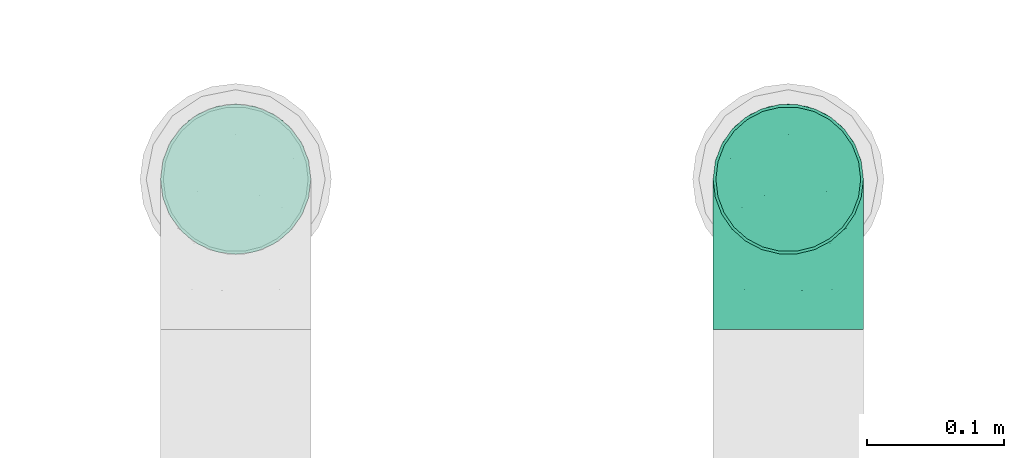
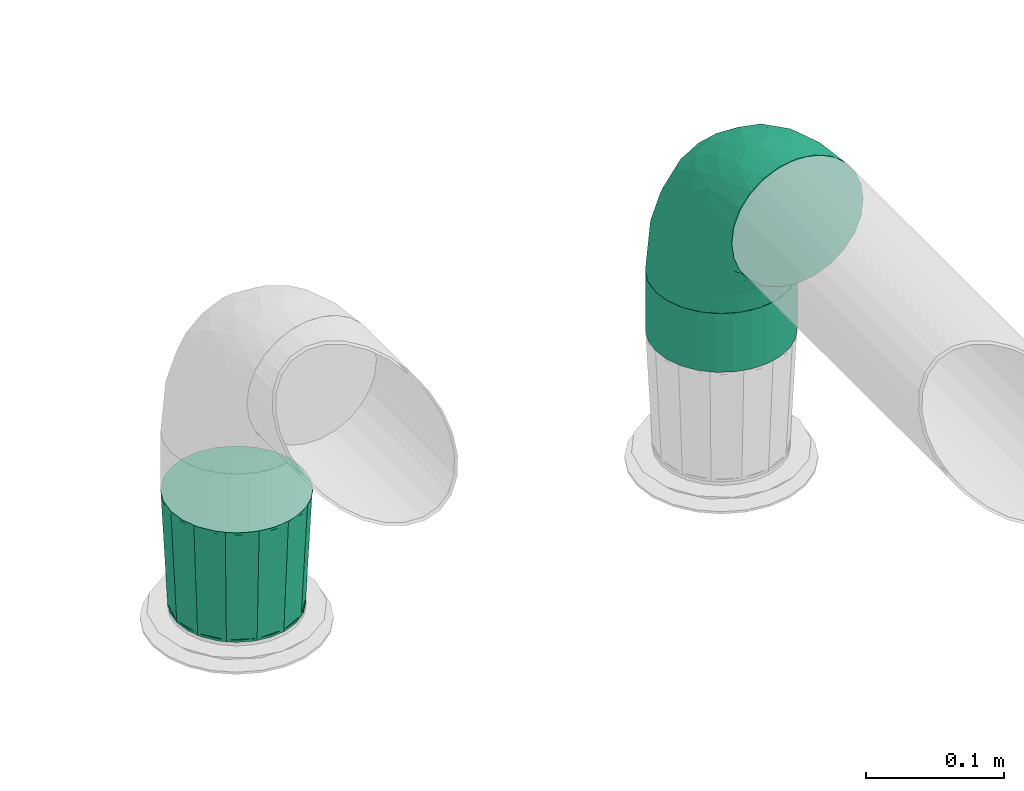
# One storey, part 33 of 115: 2 flow fittings, 1 flow segment.
"""IFC2X3 building model written with IfcOpenShell, lengths in millimetres."""

from ifc_helpers import new_model, entity, si_unit, converted_unit, derived_unit, direction, frame, origin_with_axes, origin_2d_with_axis, place, context, subcontext, project, spatial, hollow_circle, extrude, open_shell, surface_model, source, transform, mapped, material, layer, layer_set, layer_usage, type_object, element, save


model = new_model("IFC2X3")

# Units and contexts
model_context = context("Model", 3, precision=1e-05, world=origin_with_axes(), true_north=direction((0.0, 1.0)))
body_context = subcontext(model_context, "Body", "Model", "MODEL_VIEW")
ifc_project = project(units=[si_unit("AREAUNIT", "SQUARE_METRE"), si_unit("VOLUMEUNIT", "CUBIC_METRE", prefix="DECI"), si_unit("TIMEUNIT", "SECOND"), si_unit("THERMODYNAMICTEMPERATUREUNIT", "DEGREE_CELSIUS"), si_unit("PRESSUREUNIT", "PASCAL"), si_unit("MASSUNIT", "GRAM", prefix="KILO"), si_unit("LENGTHUNIT", "METRE", prefix="MILLI"), si_unit("POWERUNIT", "WATT"), si_unit("ELECTRICCURRENTUNIT", "AMPERE"), si_unit("ELECTRICVOLTAGEUNIT", "VOLT"), derived_unit("VOLUMETRICFLOWRATEUNIT", [(si_unit("VOLUMEUNIT", "CUBIC_METRE", prefix="DECI"), 1), (si_unit("TIMEUNIT", "SECOND"), -1)]), derived_unit("LINEARVELOCITYUNIT", [(si_unit("LENGTHUNIT", "METRE"), 1), (si_unit("TIMEUNIT", "SECOND"), -1)]), derived_unit("MASSDENSITYUNIT", [(si_unit("MASSUNIT", "GRAM", prefix="KILO"), 1), (si_unit("VOLUMEUNIT", "CUBIC_METRE"), -1)]), converted_unit("PLANEANGLEUNIT", "DEGREE", entity("IfcRatioMeasure", 0.01745), si_unit("PLANEANGLEUNIT", "RADIAN"), dimensions=[0, 0, 0, 0, 0, 0, 0])], contexts=[model_context])

# Site, building, storey
site_placement = place(None, origin_with_axes())
site = spatial("IfcSite", under=ifc_project, at=site_placement, CompositionType="ELEMENT")
building_placement = place(site_placement, origin_with_axes())
building = spatial("IfcBuilding", under=site, at=building_placement, Name="mc-building", CompositionType="ELEMENT")
storey_placement = place(building_placement, frame((0.0, 0.0, 2950.0), z_axis=(0.0, 0.0, 1.0), x_axis=(1.0, 0.0, 0.0)))
storey = spatial("IfcBuildingStorey", under=building, at=storey_placement, Name="2. Korrus", CompositionType="ELEMENT", Elevation=2950.0)

# Flow segment
ifc_material = material(Name="FZ1")
ifc_layer = layer(ifc_material, 0.0)
ifc_layer_set = layer_set([ifc_layer], Name="FZ1")
ifc_layer_usage = layer_usage(ifc_layer_set, "AXIS1", "POSITIVE", 0.0)
duct_segment_type = type_object("IfcDuctSegmentType", PredefinedType="RIGIDSEGMENT")
shared_shape_1 = source(origin_with_axes(), body_context, "Body", "SweptSolid", [
    extrude(hollow_circle(Radius=55.0, WallThickness=2.0, at=origin_2d_with_axis()), frame((0.0, 0.0, 0.0), z_axis=(1.0, 0.0, 0.0), x_axis=(0.0, 1.0, 0.0)), (0.0, 0.0, 1.0), 51.9),
])
flow_segment_placement = place(storey_placement, frame((16200.78197, 4393.85998, 2355.0), z_axis=(0.0, -1.0, 0.0), x_axis=(0.0, 0.0, -1.0)))
element("IfcFlowSegment", 1, at=flow_segment_placement, inside=storey, type_object=duct_segment_type, material=ifc_layer_usage, context=body_context, shape_type="MappedRepresentation", body=[
    mapped(shared_shape_1, transform((0.0, 0.0, 0.0), scale=1.0)),
])

# Flow fittings
duct_fitting_type_1 = type_object("IfcDuctFittingType", Name="BU", PredefinedType="BEND")
shared_shape_2 = source(origin_with_axes(), body_context, "Body", "SurfaceModel", [
    surface_model("IfcShellBasedSurfaceModel", [(-110.0, 0.0, -55.0), (-110.0, -14.23505, -53.12592), (-110.0, 14.23505, -53.12592), (-110.0, 53.12592, 14.23505), (-110.0, 27.5, -47.63139), (-110.0, 38.89087, -38.89087), (-110.0, -55.0, 0.0), (-110.0, -53.12592, 14.23505), (-110.0, -38.89087, -38.89087), (-110.0, -27.5, -47.63139), (-110.0, -53.12592, -14.23505), (-110.0, -47.63139, -27.5), (-110.0, -14.23505, 53.12592), (-110.0, 14.23505, 53.12592), (-110.0, 27.5, 47.63139), (-110.0, -47.63139, 27.5), (-110.0, -38.89087, 38.89087), (-110.0, -27.5, 47.63139), (-110.0, 0.0, 55.0), (-110.0, 55.0, 0.0), (-110.0, 53.12592, -14.23505), (-110.0, 47.63139, -27.5), (-110.0, 47.63139, 27.5), (-110.0, 38.89087, 38.89087), (-14.23505, 110.0, -53.12592), (-55.0, 110.0, 0.0), (0.0, 110.0, -55.0), (-27.5, 110.0, -47.63139), (-38.89087, 110.0, -38.89087), (-47.63139, 110.0, -27.5), (38.89087, 110.0, -38.89087), (53.12592, 110.0, 14.23505), (27.5, 110.0, -47.63139), (14.23505, 110.0, -53.12592), (47.63139, 110.0, -27.5), (53.12592, 110.0, -14.23505), (55.0, 110.0, 0.0), (-53.12592, 110.0, -14.23505), (-53.12592, 110.0, 14.23505), (-47.63139, 110.0, 27.5), (-38.89087, 110.0, 38.89087), (-27.5, 110.0, 47.63139), (0.0, 110.0, 55.0), (-14.23505, 110.0, 53.12592), (38.89087, 110.0, 38.89087), (47.63139, 110.0, 27.5), (27.5, 110.0, 47.63139), (14.23505, 110.0, 53.12592), (-64.21732, 48.68956, 43.63444), (-76.6405, 38.18013, 45.55988), (-60.44912, 32.56953, 51.94617), (-76.00813, 5.38378, 55.0), (-90.15553, 11.94394, 54.09138), (-78.5998, 26.77405, 50.81338), (-70.18771, 18.55163, 54.03432), (-75.55424, 54.2118, 32.41257), (-93.27622, 45.77614, 33.48188), (-96.12334, 22.13664, 50.81337), (-21.00813, 45.34362, 55.0), (-18.36258, 70.48427, 54.04484), (-32.04182, 59.64019, 52.24446), (-63.88653, 74.77858, 17.99134), (-74.66383, 63.08407, 19.92123), (-63.60674, 66.07878, 29.97482), (-99.597, 52.72185, 18.52927), (-93.11138, 56.59448, 10.50359), (-98.21577, 57.34403, 0.0), (-53.42855, 92.60092, 21.04759), (-88.54852, 54.8376, 21.04759), (-11.86161, 90.23965, 54.10313), (-5.38378, 76.00813, 55.0), (-57.34403, 98.21577, 0.0), (-56.64619, 93.12774, 10.22088), (-45.34362, 21.00813, 55.0), (-44.60838, 44.60838, 52.13415), (-92.68484, 35.46673, 43.63443), (-22.25266, 95.40765, 50.81337), (-35.97783, 90.61597, 43.63443), (-43.70931, 69.58671, 44.47149), (-27.23711, 77.39884, 50.81337), (-57.2828, 79.3123, 24.9774), (-58.67786, 84.31125, 16.04456), (-82.93277, 60.36161, 12.91784), (-49.88337, 54.51816, 47.224), (-74.57753, 66.83759, 9.55742), (-45.35812, 94.97281, 33.48188), (-59.18663, 88.95241, 0.0), (-51.517, 78.6292, 33.48188), (-65.14788, 80.03077, 0.0), (-56.45322, 62.06476, 39.63545), (-88.95241, 59.18663, 0.0), (-71.10913, 71.10913, 0.0), (-80.03077, 65.14788, 0.0), (-94.9309, 45.36788, -33.48188), (-93.11358, 56.60141, -10.46614), (-99.64997, 52.79499, -18.30015), (-90.20425, 36.08686, -43.63443), (-79.99933, 46.56772, -37.92748), (-76.00813, 5.38378, -55.0), (-72.75364, 19.68651, -53.60527), (-45.34362, 21.00813, -55.0), (-21.91957, 65.12078, -53.85897), (-5.38378, 76.00813, -55.0), (-21.00813, 45.34362, -55.0), (-35.41876, 92.89265, -43.63443), (-91.10309, 11.02766, -54.21832), (-45.77614, 93.27622, -33.48188), (-90.50474, 23.21022, -50.81337), (-70.92854, 33.31794, -49.51754), (-78.52933, 63.35627, -11.73997), (-24.91508, 84.05606, -50.81337), (-88.78941, 54.74452, -21.04759), (-69.59921, 57.34866, -33.48187), (-73.36422, 62.46673, -22.94182), (-63.49062, 67.59111, -28.46929), (-56.59448, 93.11138, -10.50359), (-54.8376, 88.54852, -21.04759), (-54.10679, 75.85581, -32.31867), (-57.75956, 31.09612, -52.80882), (-52.72185, 99.597, -18.52927), (-12.62913, 89.46304, -53.99097), (-34.46825, 66.46123, -50.04329), (-43.9837, 43.9837, -52.42279), (-65.78527, 72.58348, -17.68796), (-70.34468, 43.65295, -44.21951), (-57.47001, 51.99467, -44.91465), (-60.72547, 82.29174, -12.88567), (-42.34915, 74.24548, -43.63444), (-57.25194, 63.5016, -38.08211), (-80.95344, 53.56991, -29.32027), (-52.32891, 4.55257, -54.0482), (32.52942, 47.13398, -30.48571), (14.88266, 20.92917, -33.7947), (14.95561, 36.05775, -42.26543), (30.24048, 70.09027, -41.7461), (19.3559, 65.35825, -48.00507), (-70.35075, -46.44478, -19.5952), (-47.13398, -32.52942, -30.48571), (-28.49299, -30.5778, -16.4009), (-4.55257, 52.32891, -54.0482), (-22.4954, 22.4954, -53.25347), (-75.47368, -11.22546, -52.60718), (-81.32209, -51.5606, -9.98467), (-80.81763, -41.84862, -32.14655), (-70.09027, -30.24048, -41.7461), (-36.05774, -14.95561, -42.26543), (-9.15831, -10.852, -27.8997), (-65.35825, -19.3559, -48.00507), (11.22546, 75.47368, -52.60718), (3.94376, 43.9333, -50.53315), (-13.39742, 13.39743, -48.13058), (-43.9333, -3.94376, -50.53315), (49.37776, 67.29486, 0.0), (41.8609, 47.82256, -9.92641), (50.20582, 74.51695, -9.9731), (18.93131, 11.7156, -17.56239), (-27.5, -32.89419, 0.0), (-1.23348, -12.25375, -12.18106), (41.84862, 80.81763, -32.14655), (35.70604, 41.31408, -20.38235), (46.44478, 70.35075, -19.5952), (32.89419, 27.5, 0.0), (6.67262, -6.67262, 0.0), (-67.29486, -49.37776, 0.0), (-50.36265, -42.95545, -9.51562), (-5.47251, 5.47251, -39.92906), (-70.35075, -46.44478, 19.5952), (-74.51695, -50.20582, 9.9731), (-41.31407, -35.70604, 20.38235), (-47.13398, -32.52942, 30.48571), (-80.81763, -41.84862, 32.14655), (-4.55257, 52.32891, 54.0482), (11.22546, 75.47368, 52.60718), (-43.9333, -3.94376, 50.53315), (-65.35825, -19.3559, 48.00507), (-36.05774, -14.95561, 42.26543), (-70.09027, -30.24048, 41.7461), (-11.7156, -18.93131, 17.56239), (30.5778, 28.49299, 16.4009), (12.25375, 1.23348, 12.18106), (51.5606, 81.32209, 9.98467), (42.95545, 50.36265, 9.51562), (-75.47368, -11.22546, 52.60718), (-52.32891, 4.55257, 54.0482), (3.94376, 43.9333, 50.53315), (-22.4954, 22.4954, 53.25347), (-13.39742, 13.39743, 48.13058), (10.852, 9.15831, 27.8997), (-20.92916, -14.88266, 33.79469), (-47.82256, -41.8609, 9.92641), (32.52942, 47.13398, 30.48571), (46.44478, 70.35075, 19.5952), (41.84862, 80.81763, 32.14655), (30.24048, 70.09027, 41.7461), (19.3559, 65.35825, 48.00507), (14.95561, 36.05775, 42.26543), (-5.47251, 5.47251, 39.92906)], [open_shell([[[0, 1, 2]], [[2, 3, 4]], [[4, 3, 5]], [[2, 6, 7]], [[8, 6, 9]], [[1, 9, 6]], [[10, 6, 11]], [[8, 11, 6]], [[6, 2, 1]], [[12, 13, 14]], [[15, 2, 7]], [[16, 17, 2]], [[2, 17, 12]], [[12, 18, 13]], [[19, 20, 3]], [[5, 3, 21]], [[20, 21, 3]], [[22, 3, 2]], [[23, 22, 2]], [[12, 14, 2]], [[2, 14, 23]], [[15, 16, 2]], [[24, 25, 26]], [[27, 25, 24]], [[25, 28, 29]], [[28, 25, 27]], [[30, 26, 31]], [[26, 30, 32]], [[32, 33, 26]], [[34, 31, 35]], [[31, 34, 30]], [[35, 31, 36]], [[29, 37, 25]], [[38, 39, 26]], [[39, 40, 26]], [[41, 42, 40]], [[42, 26, 40]], [[42, 41, 43]], [[26, 44, 45]], [[31, 26, 45]], [[26, 46, 44]], [[47, 46, 26]], [[42, 47, 26]], [[25, 38, 26]], [[48, 49, 50]], [[18, 51, 52]], [[53, 54, 50]], [[55, 56, 49]], [[56, 22, 23]], [[13, 57, 14]], [[58, 59, 60]], [[61, 62, 63]], [[3, 64, 65]], [[53, 52, 54]], [[3, 65, 66]], [[67, 39, 38]], [[56, 68, 64]], [[65, 64, 68]], [[69, 59, 70]], [[38, 71, 72]], [[73, 58, 74]], [[75, 49, 56]], [[76, 69, 43]], [[53, 57, 52]], [[77, 78, 79]], [[41, 76, 43]], [[43, 69, 42]], [[55, 68, 56]], [[23, 14, 75]], [[76, 77, 79]], [[80, 67, 81]], [[62, 82, 68]], [[60, 78, 83]], [[62, 84, 82]], [[85, 77, 40]], [[81, 67, 72]], [[86, 72, 71]], [[87, 85, 67]], [[61, 81, 88]], [[77, 41, 40]], [[78, 77, 87]], [[23, 75, 56]], [[83, 89, 48]], [[85, 40, 39]], [[62, 68, 55]], [[89, 87, 63]], [[83, 48, 50]], [[57, 75, 14]], [[49, 75, 53]], [[67, 85, 39]], [[87, 77, 85]], [[63, 62, 55]], [[89, 55, 48]], [[80, 63, 87]], [[66, 65, 90]], [[66, 19, 3]], [[84, 91, 92]], [[92, 90, 82]], [[65, 82, 90]], [[61, 84, 62]], [[92, 82, 84]], [[68, 82, 65]], [[3, 22, 64]], [[56, 64, 22]], [[38, 25, 71]], [[81, 72, 86]], [[38, 72, 67]], [[91, 61, 88]], [[80, 81, 61]], [[63, 80, 61]], [[67, 80, 87]], [[77, 76, 41]], [[79, 59, 69]], [[79, 69, 76]], [[42, 69, 70]], [[60, 59, 79]], [[58, 70, 59]], [[78, 60, 79]], [[58, 60, 74]], [[52, 57, 13]], [[75, 57, 53]], [[18, 52, 13]], [[52, 51, 54]], [[51, 73, 54]], [[50, 73, 74]], [[73, 50, 54]], [[50, 74, 83]], [[60, 83, 74]], [[89, 83, 78]], [[87, 89, 78]], [[55, 89, 63]], [[50, 49, 53]], [[55, 49, 48]], [[81, 86, 88]], [[91, 84, 61]], [[5, 21, 93]], [[90, 94, 66]], [[20, 94, 95]], [[96, 93, 97]], [[98, 99, 100]], [[96, 4, 5]], [[101, 102, 103]], [[28, 27, 104]], [[2, 105, 0]], [[104, 106, 28]], [[99, 105, 107]], [[108, 107, 96]], [[90, 109, 94]], [[107, 2, 4]], [[20, 66, 94]], [[27, 24, 110]], [[109, 111, 94]], [[112, 113, 114]], [[37, 115, 71]], [[116, 106, 117]], [[99, 118, 100]], [[116, 115, 119]], [[37, 119, 115]], [[24, 120, 110]], [[121, 110, 101]], [[119, 106, 116]], [[101, 110, 120]], [[122, 103, 100]], [[117, 123, 116]], [[124, 125, 108]], [[115, 116, 126]], [[106, 29, 28]], [[26, 102, 120]], [[127, 104, 110]], [[97, 124, 96]], [[125, 122, 118]], [[128, 127, 125]], [[96, 5, 93]], [[115, 126, 86]], [[117, 106, 127]], [[111, 113, 129]], [[95, 93, 21]], [[97, 129, 112]], [[110, 104, 27]], [[106, 104, 127]], [[96, 107, 4]], [[99, 107, 108]], [[99, 108, 118]], [[105, 99, 98]], [[112, 114, 128]], [[121, 125, 127]], [[20, 19, 66]], [[109, 90, 92]], [[94, 111, 95]], [[91, 123, 109]], [[129, 113, 112]], [[93, 95, 111]], [[21, 20, 95]], [[71, 115, 86]], [[71, 25, 37]], [[123, 91, 88]], [[126, 116, 123]], [[123, 88, 126]], [[86, 126, 88]], [[37, 29, 119]], [[106, 119, 29]], [[129, 93, 111]], [[124, 112, 125]], [[0, 105, 98]], [[107, 105, 2]], [[125, 118, 108]], [[100, 118, 122]], [[93, 129, 97]], [[113, 111, 109]], [[109, 123, 113]], [[114, 123, 117]], [[123, 114, 113]], [[128, 114, 117]], [[127, 128, 117]], [[112, 128, 125]], [[103, 122, 101]], [[110, 121, 127]], [[101, 122, 121]], [[125, 121, 122]], [[26, 120, 24]], [[101, 120, 102]], [[96, 124, 108]], [[92, 91, 109]], [[112, 124, 97]], [[100, 130, 98]], [[131, 132, 133]], [[32, 134, 135]], [[136, 137, 138]], [[139, 140, 103]], [[98, 141, 0]], [[142, 10, 136]], [[143, 144, 137]], [[6, 10, 142]], [[137, 145, 146]], [[144, 147, 145]], [[143, 136, 11]], [[11, 136, 10]], [[8, 143, 11]], [[148, 149, 139]], [[8, 9, 144]], [[9, 1, 147]], [[130, 141, 98]], [[103, 140, 100]], [[148, 135, 149]], [[150, 151, 140]], [[152, 153, 154]], [[130, 140, 151]], [[148, 26, 33]], [[147, 1, 141]], [[155, 146, 132]], [[156, 138, 157]], [[134, 30, 158]], [[150, 140, 149]], [[158, 30, 34]], [[30, 134, 32]], [[153, 159, 160]], [[131, 160, 159]], [[144, 145, 137]], [[36, 152, 154]], [[146, 138, 137]], [[155, 161, 162]], [[158, 160, 131]], [[133, 149, 135]], [[156, 163, 164]], [[163, 142, 164]], [[139, 103, 102]], [[153, 152, 161]], [[34, 35, 160]], [[162, 157, 155]], [[132, 165, 133]], [[157, 146, 155]], [[140, 130, 100]], [[141, 130, 151]], [[141, 151, 147]], [[141, 1, 0]], [[102, 26, 148]], [[140, 139, 149]], [[102, 148, 139]], [[135, 33, 32]], [[151, 150, 145]], [[9, 147, 144]], [[151, 145, 147]], [[145, 165, 146]], [[135, 148, 33]], [[133, 135, 134]], [[131, 133, 134]], [[133, 165, 150]], [[133, 150, 149]], [[145, 150, 165]], [[132, 131, 159]], [[146, 165, 132]], [[160, 158, 34]], [[134, 158, 131]], [[144, 143, 8]], [[136, 143, 137]], [[155, 153, 161]], [[154, 153, 160]], [[153, 155, 159]], [[132, 159, 155]], [[160, 35, 154]], [[36, 154, 35]], [[164, 136, 138]], [[6, 142, 163]], [[136, 164, 142]], [[156, 164, 138]], [[156, 157, 162]], [[146, 157, 138]], [[15, 7, 166]], [[6, 163, 167]], [[168, 169, 166]], [[166, 169, 170]], [[171, 172, 70]], [[173, 174, 175]], [[17, 176, 174]], [[177, 156, 162]], [[176, 16, 170]], [[170, 16, 15]], [[161, 178, 179]], [[152, 180, 181]], [[182, 173, 183]], [[18, 12, 182]], [[184, 185, 186]], [[183, 185, 73]], [[183, 73, 51]], [[177, 187, 188]], [[189, 168, 166]], [[187, 178, 190]], [[16, 176, 17]], [[161, 152, 181]], [[45, 191, 31]], [[45, 44, 192]], [[192, 191, 45]], [[180, 36, 31]], [[193, 194, 195]], [[46, 47, 194]], [[193, 195, 190]], [[193, 44, 46]], [[172, 42, 70]], [[185, 58, 73]], [[189, 163, 156]], [[163, 189, 167]], [[70, 58, 171]], [[184, 171, 185]], [[169, 188, 175]], [[180, 31, 191]], [[192, 193, 190]], [[191, 190, 178]], [[182, 174, 173]], [[194, 47, 172]], [[190, 195, 187]], [[186, 185, 173]], [[162, 179, 177]], [[188, 196, 175]], [[179, 187, 177]], [[185, 171, 58]], [[172, 171, 184]], [[172, 184, 194]], [[172, 47, 42]], [[51, 18, 182]], [[185, 183, 173]], [[51, 182, 183]], [[174, 12, 17]], [[184, 186, 195]], [[46, 194, 193]], [[184, 195, 194]], [[195, 196, 187]], [[174, 182, 12]], [[175, 174, 176]], [[169, 175, 176]], [[175, 196, 186]], [[175, 186, 173]], [[195, 186, 196]], [[188, 169, 168]], [[187, 196, 188]], [[166, 170, 15]], [[176, 170, 169]], [[193, 192, 44]], [[191, 192, 190]], [[177, 189, 156]], [[167, 189, 166]], [[189, 177, 168]], [[188, 168, 177]], [[166, 7, 167]], [[6, 167, 7]], [[181, 191, 178]], [[36, 180, 152]], [[191, 181, 180]], [[161, 181, 178]], [[161, 179, 162]], [[187, 179, 178]]])]),
])
flow_fitting_1_placement = place(storey_placement, frame((16200.78197, 4393.85998, 2465.0), z_axis=(-1.0, 0.0, 0.0), x_axis=(0.0, 1.0, 0.0)))
element("IfcFlowFitting", 2, at=flow_fitting_1_placement, inside=storey, type_object=duct_fitting_type_1, Name="BU", context=body_context, shape_type="MappedRepresentation", body=[
    mapped(shared_shape_2, transform((0.0, 0.0, 0.0), scale=1.0)),
])
duct_fitting_type_2 = type_object("IfcDuctFittingType", PredefinedType="TRANSITION")
shared_shape_3 = source(origin_with_axes(), body_context, "Body", "SurfaceModel", [
    surface_model("IfcShellBasedSurfaceModel", [(100.0, -55.0, 0.0), (100.0, -12.23865, 53.62104), (100.0, -34.29194, 43.00073), (100.0, 49.55329, 23.86361), (100.0, 34.29194, 43.00073), (100.0, 49.55329, -23.86361), (0.0, -45.04844, -21.69419), (0.0, -50.0, 0.0), (0.0, -45.04844, 21.69419), (0.0, 31.17449, 39.09157), (0.0, 45.04844, 21.69419), (0.0, 50.0, 0.0), (98.0, 47.63139, 27.5), (98.0, 0.0, 55.0), (98.0, 38.89087, 38.89087), (98.0, -38.89087, 38.89087), (98.0, -47.63139, 27.5), (100.0, 12.23865, 53.62104), (100.0, -49.55329, 23.86361), (100.0, 55.0, 0.0), (100.0, 12.23865, -53.62104), (100.0, 34.29194, -43.00073), (100.0, -49.55329, -23.86361), (100.0, -34.29194, -43.00073), (100.0, -12.23865, -53.62104), (0.0, -31.17449, 39.09157), (0.0, -11.12605, 48.7464), (0.0, 11.12605, 48.7464), (0.0, -31.17449, -39.09157), (0.0, 11.12605, -48.7464), (0.0, -11.12605, -48.7464), (0.0, 45.04844, -21.69419), (0.0, 31.17449, -39.09157), (0.0, 47.52422, -10.84709), (0.0, 38.11147, -30.39288), (100.0, 41.92261, -33.43217), (100.0, -41.92261, -33.43217), (0.0, -38.11147, -30.39288), (100.0, 23.2653, -48.31088), (0.0, 21.15027, -43.91899), (100.0, 52.32388, -11.72483), (0.0, 0.0, -48.7464), (100.0, 0.0, -53.62104), (0.0, -21.15027, -43.91899), (100.0, -23.2653, -48.31088), (0.0, -47.52422, -10.84709), (100.0, -52.32388, -11.72483), (0.0, -47.52422, 10.84709), (0.0, -38.11147, 30.39288), (100.0, -41.92261, 33.43217), (100.0, 41.92261, 33.43217), (0.0, 38.11147, 30.39288), (100.0, -23.2653, 48.31088), (0.0, -21.15027, 43.91899), (100.0, -52.32388, 11.72483), (0.0, 0.0, 48.7464), (100.0, 0.0, 53.62104), (0.0, 21.15027, 43.91899), (100.0, 23.2653, 48.31088), (0.0, 47.52422, 10.84709), (100.0, 52.32388, 11.72483), (100.0, -14.23505, -53.12592), (100.0, 0.0, -55.0), (100.0, -27.5, -47.63139), (100.0, 27.5, -47.63139), (100.0, -38.89087, -38.89087), (100.0, -53.12592, -14.23505), (100.0, -47.63139, -27.5), (100.0, -47.63139, 27.5), (100.0, 14.23505, -53.12592), (100.0, 38.89087, -38.89087), (100.0, 47.63139, -27.5), (100.0, 47.63139, 27.5), (100.0, 53.12592, -14.23505), (100.0, -53.12592, 14.23505), (100.0, -38.89087, 38.89087), (100.0, -27.5, 47.63139), (100.0, 0.0, 55.0), (100.0, -14.23505, 53.12592), (100.0, 53.12592, 14.23505), (100.0, 38.89087, 38.89087), (100.0, 27.5, 47.63139), (100.0, 14.23505, 53.12592), (98.0, -27.5, 47.63139), (98.0, -14.23505, 53.12592), (98.0, -53.12592, -14.23505), (98.0, 14.23505, 53.12592), (98.0, 27.5, 47.63139), (98.0, 53.12592, 14.23505), (98.0, 55.0, 0.0), (98.0, -47.63139, -27.5), (98.0, -53.12592, 14.23505), (98.0, 27.5, -47.63139), (98.0, -27.5, -47.63139), (98.0, -38.89087, -38.89087), (98.0, 0.0, -55.0), (98.0, -14.23505, -53.12592), (98.0, 38.89087, -38.89087), (98.0, 47.63139, -27.5), (98.0, 53.12592, -14.23505), (98.0, 14.23505, -53.12592), (98.0, -55.0, 0.0), (0.0, 0.0, 50.0), (0.0, 35.35534, 35.35534), (0.0, -12.94095, 48.29629), (0.0, -25.0, 43.30127), (0.0, -35.35534, 35.35534), (0.0, -48.29629, 12.94095), (0.0, -43.30127, 25.0), (0.0, 25.0, 43.30127), (0.0, 12.94095, 48.29629), (0.0, 43.30127, 25.0), (0.0, 48.29629, 12.94095), (0.0, 25.0, -43.30127), (0.0, 48.29629, -12.94095), (0.0, -48.29629, -12.94095), (0.0, -43.30127, -25.0), (0.0, -12.94095, -48.29629), (0.0, -25.0, -43.30127), (0.0, -35.35534, -35.35534), (0.0, 43.30127, -25.0), (0.0, 35.35534, -35.35534), (0.0, 12.94095, -48.29629), (0.0, 0.0, -50.0), (2.0, -35.35534, -35.35534), (2.0, -25.0, -43.30127), (2.0, -12.94095, -48.29629), (2.0, -43.30127, -25.0), (2.0, 0.0, -50.0), (2.0, -48.29629, -12.94095), (2.0, -50.0, 0.0), (2.0, 12.94095, -48.29629), (2.0, 25.0, -43.30127), (2.0, 43.30127, -25.0), (2.0, 48.29629, -12.94095), (2.0, 35.35534, -35.35534), (2.0, -48.29629, 12.94095), (2.0, -35.35534, 35.35534), (2.0, -43.30127, 25.0), (2.0, 35.35534, 35.35534), (2.0, -12.94095, 48.29629), (2.0, -25.0, 43.30127), (2.0, 0.0, 50.0), (2.0, 43.30127, 25.0), (2.0, 48.29629, 12.94095), (2.0, 50.0, 0.0), (2.0, 25.0, 43.30127), (2.0, 12.94095, 48.29629)], [open_shell([[[0, 1, 2]], [[3, 4, 5]], [[6, 7, 8]], [[9, 10, 11]], [[12, 13, 14]], [[15, 13, 16]], [[0, 4, 17]], [[2, 18, 0]], [[1, 0, 17]], [[3, 5, 19]], [[20, 21, 5]], [[22, 20, 5]], [[22, 5, 0]], [[22, 23, 24]], [[22, 24, 20]], [[4, 0, 5]], [[8, 25, 6]], [[6, 25, 26]], [[6, 26, 27]], [[11, 27, 9]], [[28, 6, 29]], [[30, 28, 29]], [[31, 6, 11]], [[31, 32, 29]], [[31, 29, 6]], [[27, 11, 6]], [[31, 33, 5]], [[34, 35, 32]], [[36, 22, 6]], [[36, 37, 23]], [[38, 29, 39]], [[33, 40, 5]], [[33, 11, 40]], [[19, 40, 11]], [[32, 21, 39]], [[32, 35, 21]], [[34, 31, 35]], [[30, 41, 42]], [[28, 43, 44]], [[42, 41, 20]], [[7, 45, 46]], [[38, 39, 21]], [[46, 0, 7]], [[6, 37, 36]], [[38, 20, 29]], [[43, 30, 24]], [[42, 24, 30]], [[28, 23, 37]], [[6, 22, 45]], [[35, 31, 5]], [[44, 43, 24]], [[20, 41, 29]], [[46, 45, 22]], [[44, 23, 28]], [[8, 47, 18]], [[48, 49, 25]], [[50, 3, 10]], [[50, 51, 4]], [[52, 26, 53]], [[47, 54, 18]], [[47, 7, 54]], [[0, 54, 7]], [[25, 2, 53]], [[25, 49, 2]], [[48, 8, 49]], [[27, 55, 56]], [[9, 57, 58]], [[56, 55, 1]], [[11, 59, 60]], [[52, 53, 2]], [[60, 19, 11]], [[10, 51, 50]], [[52, 1, 26]], [[57, 27, 17]], [[56, 17, 27]], [[9, 4, 51]], [[10, 3, 59]], [[49, 8, 18]], [[58, 57, 17]], [[1, 55, 26]], [[60, 59, 3]], [[58, 4, 9]], [[61, 62, 63]], [[63, 64, 65]], [[66, 67, 68]], [[65, 64, 67]], [[67, 64, 68]], [[69, 64, 62]], [[64, 63, 62]], [[70, 71, 64]], [[72, 64, 71]], [[71, 73, 19]], [[74, 0, 66]], [[72, 68, 64]], [[75, 68, 76]], [[77, 78, 76]], [[72, 76, 68]], [[76, 72, 77]], [[79, 72, 19]], [[19, 72, 71]], [[80, 81, 77]], [[77, 72, 80]], [[82, 77, 81]], [[74, 66, 68]], [[83, 84, 13]], [[15, 83, 13]], [[12, 16, 13]], [[16, 12, 85]], [[86, 87, 13]], [[87, 14, 13]], [[88, 89, 12]], [[89, 90, 12]], [[91, 16, 85]], [[90, 85, 12]], [[89, 92, 90]], [[93, 94, 95]], [[95, 94, 90]], [[96, 93, 95]], [[97, 92, 98]], [[98, 89, 99]], [[100, 95, 92]], [[92, 89, 98]], [[90, 92, 95]], [[101, 91, 85]], [[89, 73, 99]], [[99, 71, 98]], [[92, 97, 64]], [[70, 97, 98]], [[100, 92, 69]], [[73, 71, 99]], [[89, 19, 73]], [[92, 64, 69]], [[64, 97, 70]], [[98, 71, 70]], [[100, 69, 62]], [[62, 95, 100]], [[95, 61, 96]], [[96, 63, 93]], [[90, 94, 67]], [[65, 94, 93]], [[85, 90, 66]], [[63, 65, 93]], [[96, 61, 63]], [[85, 66, 0]], [[66, 90, 67]], [[94, 65, 67]], [[85, 0, 101]], [[62, 61, 95]], [[101, 74, 91]], [[91, 68, 16]], [[83, 15, 76]], [[75, 15, 16]], [[84, 83, 78]], [[74, 68, 91]], [[101, 0, 74]], [[83, 76, 78]], [[76, 15, 75]], [[16, 68, 75]], [[84, 78, 77]], [[77, 13, 84]], [[13, 82, 86]], [[86, 81, 87]], [[12, 14, 72]], [[80, 14, 87]], [[88, 12, 79]], [[81, 80, 87]], [[86, 82, 81]], [[88, 79, 19]], [[79, 12, 72]], [[14, 80, 72]], [[88, 19, 89]], [[77, 82, 13]], [[102, 103, 104]], [[105, 104, 106]], [[107, 108, 106]], [[103, 106, 104]], [[106, 103, 107]], [[109, 103, 110]], [[103, 102, 110]], [[111, 112, 103]], [[113, 103, 112]], [[112, 11, 114]], [[107, 103, 113]], [[113, 115, 107]], [[116, 115, 117]], [[117, 118, 119]], [[116, 117, 119]], [[117, 115, 113]], [[120, 121, 114]], [[113, 114, 121]], [[113, 122, 117]], [[113, 112, 114]], [[117, 122, 123]], [[7, 107, 115]], [[124, 125, 126]], [[127, 124, 126]], [[128, 129, 126]], [[127, 126, 129]], [[130, 129, 128]], [[131, 132, 128]], [[132, 130, 128]], [[133, 134, 135]], [[132, 135, 134]], [[132, 134, 130]], [[134, 136, 130]], [[137, 138, 136]], [[137, 136, 139]], [[140, 137, 139]], [[141, 137, 140]], [[142, 140, 139]], [[143, 139, 144]], [[144, 134, 145]], [[146, 147, 139]], [[139, 136, 144]], [[139, 147, 142]], [[136, 134, 144]], [[11, 134, 114]], [[114, 133, 120]], [[113, 121, 132]], [[135, 121, 120]], [[122, 113, 131]], [[134, 133, 114]], [[11, 145, 134]], [[113, 132, 131]], [[132, 121, 135]], [[120, 133, 135]], [[122, 131, 128]], [[128, 123, 122]], [[123, 126, 117]], [[117, 125, 118]], [[116, 119, 127]], [[124, 119, 118]], [[115, 116, 129]], [[125, 124, 118]], [[117, 126, 125]], [[115, 129, 130]], [[129, 116, 127]], [[119, 124, 127]], [[115, 130, 7]], [[128, 126, 123]], [[7, 136, 107]], [[107, 138, 108]], [[105, 106, 141]], [[137, 106, 108]], [[104, 105, 140]], [[136, 138, 107]], [[7, 130, 136]], [[105, 141, 140]], [[141, 106, 137]], [[108, 138, 137]], [[104, 140, 142]], [[142, 102, 104]], [[102, 147, 110]], [[110, 146, 109]], [[111, 103, 143]], [[139, 103, 109]], [[112, 111, 144]], [[146, 139, 109]], [[110, 147, 146]], [[112, 144, 145]], [[144, 111, 143]], [[103, 139, 143]], [[112, 145, 11]], [[142, 147, 102]]])]),
])
flow_fitting_2_placement = place(storey_placement, frame((15796.4103, 4393.85998, 2203.1), z_axis=(0.0, -1.0, 0.0), x_axis=(0.0, 0.0, 1.0)))
element("IfcFlowFitting", 3, at=flow_fitting_2_placement, inside=storey, type_object=duct_fitting_type_2, context=body_context, shape_type="MappedRepresentation", body=[
    mapped(shared_shape_3, transform((0.0, 0.0, 0.0), scale=1.0)),
])

save(model, "model.ifc")
